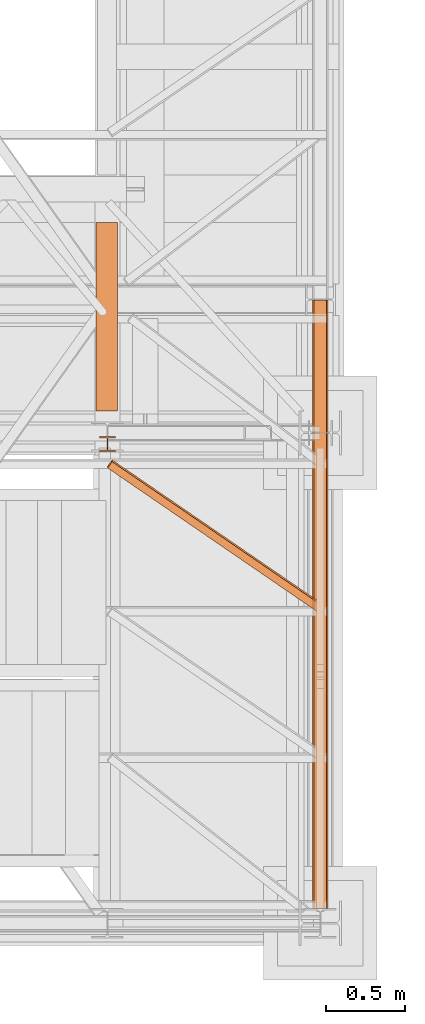
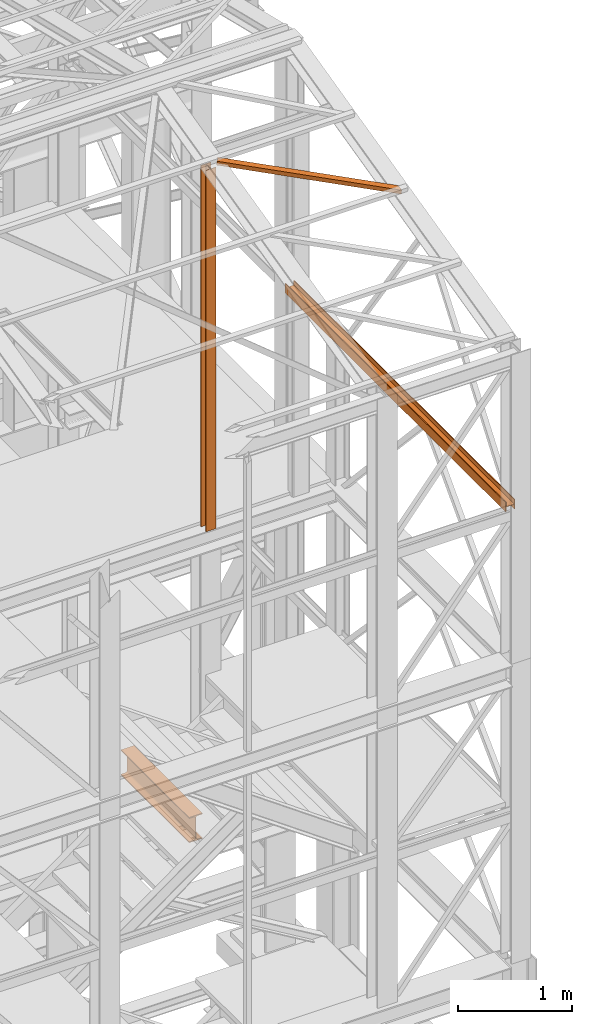
# One storey, part 57 of 208: 5 proxies.
"""IFC2X3 building model written with IfcOpenShell, lengths in millimetres."""

from ifc_helpers import new_model, entity, si_unit, converted_unit, frame, origin, origin_with_axes, place, context, subcontext, project, spatial, faceted_brep, element, save


model = new_model("IFC2X3")

# Units and contexts
model_context = context("Model", 3, precision=1e-05, world=origin())
plan_context = context("Plan", 3, precision=1e-05, world=origin())
body_context = subcontext(model_context, "Body", "Model", "MODEL_VIEW")
ifc_project = project(units=[si_unit("LENGTHUNIT", "METRE", prefix="MILLI"), converted_unit("PLANEANGLEUNIT", "DEGREE", entity("IfcPlaneAngleMeasure", 0.0174532925199433), si_unit("PLANEANGLEUNIT", "RADIAN"), dimensions=[0, 0, 0, 0, 0, 0, 0]), si_unit("AREAUNIT", "SQUARE_METRE"), si_unit("VOLUMEUNIT", "CUBIC_METRE")], contexts=[model_context, plan_context])

# Building, storey
building_placement = place(None, origin())
building = spatial("IfcBuilding", under=ifc_project, at=building_placement, CompositionType="COMPLEX")
storey_placement = place(building_placement, origin_with_axes())
storey = spatial("IfcBuildingStorey", under=building, at=storey_placement, Name="Geschoss", CompositionType="ELEMENT")

# Proxies
proxy_1_placement = place(storey_placement, frame((6650.254968528656, -25077.57438405939, 9979.990000745052), z_axis=(0.0, 0.0, 1.0), x_axis=(1.0, 0.0, 0.0)))
element("IfcBuildingElementProxy", 1, at=proxy_1_placement, inside=storey, context=body_context, shape_type="Brep", body=[
    faceted_brep([(8.010000000000218, 3856.759993674456, 0.01000000000021828), (8.010000000000218, 3856.759993674456, 47.51000000000022), (88.01000000000022, 3856.759993674456, 47.51000000000022), (88.01000000000022, 3856.759993674456, 0.01000000000021828), (96.01000000000022, 3856.759993674456, 0.01000000000021828), (96.01000000000022, 3856.759993674456, 100.0100000000002), (88.01000000000022, 3856.759993674456, 100.0100000000002), (88.01000000000022, 3856.759993674456, 52.51000000000022), (8.010000000000218, 3856.759993674456, 52.51000000000022), (8.010000000000218, 3856.759993674456, 100.0100000000002), (0.01000000000021828, 3856.759993674456, 100.0100000000002), (0.01000000000021828, 3856.759993674456, 0.01000000000021828), (0.01000000000021828, 3856.759993674456, 0.01000000000021828), (0.009999999999308784, 0.01000000000203727, 0.01000000000021828), (8.009999999999309, 0.01000000000203727, 0.01000000000021828), (8.010000000000218, 3856.759993674456, 0.01000000000021828), (0.01000000000021828, 3856.759993674456, 100.0100000000002), (0.009999999999308784, 0.01000000000203727, 100.0100000000002), (0.009999999999308784, 0.01000000000203727, 0.01000000000021828), (0.01000000000021828, 3856.759993674456, 0.01000000000021828), (8.010000000000218, 3856.759993674456, 100.0100000000002), (8.009999999999309, 0.01000000000203727, 100.0100000000002), (0.009999999999308784, 0.01000000000203727, 100.0100000000002), (0.01000000000021828, 3856.759993674456, 100.0100000000002), (8.010000000000218, 3856.759993674456, 52.51000000000022), (8.009999999999309, 0.01000000000203727, 52.51000000000022), (8.009999999999309, 0.01000000000203727, 100.0100000000002), (8.010000000000218, 3856.759993674456, 100.0100000000002), (88.01000000000022, 3856.759993674456, 52.51000000000022), (88.00999999999931, 0.01000000000203727, 52.51000000000022), (8.009999999999309, 0.01000000000203727, 52.51000000000022), (8.010000000000218, 3856.759993674456, 52.51000000000022), (88.01000000000022, 3856.759993674456, 100.0100000000002), (88.00999999999931, 0.01000000000203727, 100.0100000000002), (88.00999999999931, 0.01000000000203727, 52.51000000000022), (88.01000000000022, 3856.759993674456, 52.51000000000022), (96.01000000000022, 3856.759993674456, 100.0100000000002), (96.00999999999931, 0.01000000000203727, 100.0100000000002), (88.00999999999931, 0.01000000000203727, 100.0100000000002), (88.01000000000022, 3856.759993674456, 100.0100000000002), (96.01000000000022, 3856.759993674456, 0.01000000000021828), (96.00999999999931, 0.01000000000203727, 0.01000000000021828), (96.00999999999931, 0.01000000000203727, 100.0100000000002), (96.01000000000022, 3856.759993674456, 100.0100000000002), (88.01000000000022, 3856.759993674456, 0.01000000000021828), (88.00999999999931, 0.01000000000203727, 0.01000000000021828), (96.00999999999931, 0.01000000000203727, 0.01000000000021828), (96.01000000000022, 3856.759993674456, 0.01000000000021828), (88.01000000000022, 3856.759993674456, 47.51000000000022), (88.00999999999931, 0.01000000000203727, 47.51000000000022), (88.00999999999931, 0.01000000000203727, 0.01000000000021828), (88.01000000000022, 3856.759993674456, 0.01000000000021828), (8.010000000000218, 3856.759993674456, 47.51000000000022), (8.009999999999309, 0.01000000000203727, 47.51000000000022), (88.00999999999931, 0.01000000000203727, 47.51000000000022), (88.01000000000022, 3856.759993674456, 47.51000000000022), (8.010000000000218, 3856.759993674456, 0.01000000000021828), (8.009999999999309, 0.01000000000203727, 0.01000000000021828), (8.009999999999309, 0.01000000000203727, 47.51000000000022), (8.010000000000218, 3856.759993674456, 47.51000000000022), (8.009999999999309, 0.01000000000203727, 0.01000000000021828), (0.009999999999308784, 0.01000000000203727, 0.01000000000021828), (0.009999999999308784, 0.01000000000203727, 100.0100000000002), (8.009999999999309, 0.01000000000203727, 100.0100000000002), (8.009999999999309, 0.01000000000203727, 52.51000000000022), (88.00999999999931, 0.01000000000203727, 52.51000000000022), (88.00999999999931, 0.01000000000203727, 100.0100000000002), (96.00999999999931, 0.01000000000203727, 100.0100000000002), (96.00999999999931, 0.01000000000203727, 0.01000000000021828), (88.00999999999931, 0.01000000000203727, 0.01000000000021828), (88.00999999999931, 0.01000000000203727, 47.51000000000022), (8.009999999999309, 0.01000000000203727, 47.51000000000022)], [[[0, 1, 2, 3, 4, 5, 6, 7, 8, 9, 10, 11]], [[12, 13, 14, 15]], [[16, 17, 18, 19]], [[20, 21, 22, 23]], [[24, 25, 26, 27]], [[28, 29, 30, 31]], [[32, 33, 34, 35]], [[36, 37, 38, 39]], [[40, 41, 42, 43]], [[44, 45, 46, 47]], [[48, 49, 50, 51]], [[52, 53, 54, 55]], [[56, 57, 58, 59]], [[60, 61, 62, 63, 64, 65, 66, 67, 68, 69, 70, 71]]], orient=[[False], [False], [False], [False], [False], [False], [False], [False], [False], [False], [False], [False], [False], [False]]),
])
proxy_2_placement = place(storey_placement, frame((6650.254968528656, -25077.57438405939, 9979.990000745052), z_axis=(0.0, 0.0, 1.0), x_axis=(1.0, 0.0, 0.0)))
element("IfcBuildingElementProxy", 2, at=proxy_2_placement, inside=storey, context=body_context, shape_type="Brep", body=[
    faceted_brep([(8.010000000000218, 3856.759993674456, 0.01000000000021828), (8.010000000000218, 3856.759993674456, 47.51000000000022), (88.01000000000022, 3856.759993674456, 47.51000000000022), (88.01000000000022, 3856.759993674456, 0.01000000000021828), (96.01000000000022, 3856.759993674456, 0.01000000000021828), (96.01000000000022, 3856.759993674456, 100.0100000000002), (88.01000000000022, 3856.759993674456, 100.0100000000002), (88.01000000000022, 3856.759993674456, 52.51000000000022), (8.010000000000218, 3856.759993674456, 52.51000000000022), (8.010000000000218, 3856.759993674456, 100.0100000000002), (0.01000000000021828, 3856.759993674456, 100.0100000000002), (0.01000000000021828, 3856.759993674456, 0.01000000000021828), (0.01000000000021828, 3856.759993674456, 0.01000000000021828), (0.009999999999308784, 0.01000000000203727, 0.01000000000021828), (8.009999999999309, 0.01000000000203727, 0.01000000000021828), (8.010000000000218, 3856.759993674456, 0.01000000000021828), (0.01000000000021828, 3856.759993674456, 100.0100000000002), (0.009999999999308784, 0.01000000000203727, 100.0100000000002), (0.009999999999308784, 0.01000000000203727, 0.01000000000021828), (0.01000000000021828, 3856.759993674456, 0.01000000000021828), (8.010000000000218, 3856.759993674456, 100.0100000000002), (8.009999999999309, 0.01000000000203727, 100.0100000000002), (0.009999999999308784, 0.01000000000203727, 100.0100000000002), (0.01000000000021828, 3856.759993674456, 100.0100000000002), (8.010000000000218, 3856.759993674456, 52.51000000000022), (8.009999999999309, 0.01000000000203727, 52.51000000000022), (8.009999999999309, 0.01000000000203727, 100.0100000000002), (8.010000000000218, 3856.759993674456, 100.0100000000002), (88.01000000000022, 3856.759993674456, 52.51000000000022), (88.00999999999931, 0.01000000000203727, 52.51000000000022), (8.009999999999309, 0.01000000000203727, 52.51000000000022), (8.010000000000218, 3856.759993674456, 52.51000000000022), (88.01000000000022, 3856.759993674456, 100.0100000000002), (88.00999999999931, 0.01000000000203727, 100.0100000000002), (88.00999999999931, 0.01000000000203727, 52.51000000000022), (88.01000000000022, 3856.759993674456, 52.51000000000022), (96.01000000000022, 3856.759993674456, 100.0100000000002), (96.00999999999931, 0.01000000000203727, 100.0100000000002), (88.00999999999931, 0.01000000000203727, 100.0100000000002), (88.01000000000022, 3856.759993674456, 100.0100000000002), (96.01000000000022, 3856.759993674456, 0.01000000000021828), (96.00999999999931, 0.01000000000203727, 0.01000000000021828), (96.00999999999931, 0.01000000000203727, 100.0100000000002), (96.01000000000022, 3856.759993674456, 100.0100000000002), (88.01000000000022, 3856.759993674456, 0.01000000000021828), (88.00999999999931, 0.01000000000203727, 0.01000000000021828), (96.00999999999931, 0.01000000000203727, 0.01000000000021828), (96.01000000000022, 3856.759993674456, 0.01000000000021828), (88.01000000000022, 3856.759993674456, 47.51000000000022), (88.00999999999931, 0.01000000000203727, 47.51000000000022), (88.00999999999931, 0.01000000000203727, 0.01000000000021828), (88.01000000000022, 3856.759993674456, 0.01000000000021828), (8.010000000000218, 3856.759993674456, 47.51000000000022), (8.009999999999309, 0.01000000000203727, 47.51000000000022), (88.00999999999931, 0.01000000000203727, 47.51000000000022), (88.01000000000022, 3856.759993674456, 47.51000000000022), (8.010000000000218, 3856.759993674456, 0.01000000000021828), (8.009999999999309, 0.01000000000203727, 0.01000000000021828), (8.009999999999309, 0.01000000000203727, 47.51000000000022), (8.010000000000218, 3856.759993674456, 47.51000000000022), (8.009999999999309, 0.01000000000203727, 0.01000000000021828), (0.009999999999308784, 0.01000000000203727, 0.01000000000021828), (0.009999999999308784, 0.01000000000203727, 100.0100000000002), (8.009999999999309, 0.01000000000203727, 100.0100000000002), (8.009999999999309, 0.01000000000203727, 52.51000000000022), (88.00999999999931, 0.01000000000203727, 52.51000000000022), (88.00999999999931, 0.01000000000203727, 100.0100000000002), (96.00999999999931, 0.01000000000203727, 100.0100000000002), (96.00999999999931, 0.01000000000203727, 0.01000000000021828), (88.00999999999931, 0.01000000000203727, 0.01000000000021828), (88.00999999999931, 0.01000000000203727, 47.51000000000022), (8.009999999999309, 0.01000000000203727, 47.51000000000022)], [[[0, 1, 2, 3, 4, 5, 6, 7, 8, 9, 10, 11]], [[12, 13, 14, 15]], [[16, 17, 18, 19]], [[20, 21, 22, 23]], [[24, 25, 26, 27]], [[28, 29, 30, 31]], [[32, 33, 34, 35]], [[36, 37, 38, 39]], [[40, 41, 42, 43]], [[44, 45, 46, 47]], [[48, 49, 50, 51]], [[52, 53, 54, 55]], [[56, 57, 58, 59]], [[60, 61, 62, 63, 64, 65, 66, 67, 68, 69, 70, 71]]], orient=[[False], [False], [False], [False], [False], [False], [False], [False], [False], [False], [False], [False], [False], [False]]),
])
proxy_3_placement = place(storey_placement, frame((5349.415251226796, -23201.62230478293, 12214.24717333412), z_axis=(0.0, 0.0, 1.0), x_axis=(1.0, 0.0, 0.0)))
element("IfcBuildingElementProxy", 3, at=proxy_3_placement, inside=storey, context=body_context, shape_type="Brep", body=[
    faceted_brep([(28.82079669527775, 967.7692788621025, 232.0521250666225), (28.82079669527775, 955.9752131652676, 280.6412186405796), (0.01000000000021828, 916.2634686381462, 271.0019582749592), (0.01000000000021828, 928.0575343349847, 222.4128647010039), (1337.349720073478, 71.25499243027298, 14.44056628674844), (1337.349720073478, 59.4609267334381, 63.02965986070558), (28.82079669527775, 955.9752131652676, 280.6412186405796), (28.82079669527775, 967.7692788621025, 232.0521250666225), (1337.349720073478, 11.80406569683692, 0.01000000000021828), (1337.349720073478, 71.25499243027298, 14.44056628674844), (28.82079669527775, 967.7692788621025, 232.0521250666225), (0.01000000000021828, 928.0575343349847, 222.4128647010039), (1337.349720073478, 0.00999999999839929, 48.59909357395554), (1337.349720073478, 11.80406569683692, 0.01000000000021828), (0.01000000000021828, 928.0575343349847, 222.4128647010039), (0.01000000000021828, 916.2634686381462, 271.0019582749592), (1337.349720073478, 59.4609267334381, 63.02965986070558), (1337.349720073478, 0.00999999999839929, 48.59909357395554), (0.01000000000021828, 916.2634686381462, 271.0019582749592), (28.82079669527775, 955.9752131652676, 280.6412186405796), (1337.349720073478, 71.25499243027298, 14.44056628674844), (1337.349720073478, 11.80406569683692, 0.01000000000021828), (1337.349720073478, 0.00999999999839929, 48.59909357395554), (1337.349720073478, 59.4609267334381, 63.02965986070558)], [[[0, 1, 2, 3]], [[4, 5, 6, 7]], [[8, 9, 10, 11]], [[12, 13, 14, 15]], [[16, 17, 18, 19]], [[20, 21, 22, 23]]], orient=[[False], [False], [False], [False], [False], [False]]),
])
proxy_4_placement = place(storey_placement, frame((5276.754968338675, -21922.57438972184, 5014.990005364415), z_axis=(0.0, 0.0, 1.0), x_axis=(1.0, 0.0, 0.0)))
element("IfcBuildingElementProxy", 4, at=proxy_4_placement, inside=storey, context=body_context, shape_type="Brep", body=[
    faceted_brep([(135.0100000000002, 0.01000000000203727, 270.0100000000002), (135.0100000000002, 1194.009999593949, 270.0100000000002), (135.0100000000002, 1194.009999593949, 259.8100001907351), (135.0100000000002, 0.01000000000203727, 259.8100001907351), (135.0100000000002, 0.01000000000203727, 259.8100001907351), (135.0100000000002, 1194.009999593949, 259.8100001907351), (85.80999995231468, 1194.009999593945, 259.810000190736), (85.8099999523165, 0.01000000000203727, 259.8100001907351), (85.8099999523165, 0.01000000000203727, 259.8100001907351), (85.80999995231468, 1194.009999593945, 259.810000190736), (81.17476076017101, 1194.009999593949, 259.0757968253238), (81.17476076017192, 0.01000000000203727, 259.0757968253238), (81.17476076017192, 0.01000000000203727, 259.0757968253238), (81.17476076017101, 1194.009999593949, 259.0757968253238), (76.99323602687218, 1194.009999593945, 256.9452365592924), (76.99323602687218, 0.01000000000203727, 256.9452365592924), (76.99323602687218, 0.01000000000203727, 256.9452365592924), (76.99323602687218, 1194.009999593945, 256.9452365592924), (73.67476358375916, 1194.009999593949, 253.6267641161803), (73.67476358376007, 0.01000000000203727, 253.6267641161803), (73.67476358376007, 0.01000000000203727, 253.6267641161803), (73.67476358375916, 1194.009999593949, 253.6267641161803), (71.5442033177278, 1194.009999593949, 249.4452393828797), (71.5442033177278, 0.01000000000203727, 249.4452393828788), (71.5442033177278, 0.01000000000203727, 249.4452393828788), (71.5442033177278, 1194.009999593949, 249.4452393828797), (70.8099999523165, 1194.009999593949, 244.8100001907351), (70.8099999523165, 0.01000000000203727, 244.8100001907351), (70.8099999523165, 0.01000000000203727, 244.8100001907351), (70.8099999523165, 1194.009999593949, 244.8100001907351), (70.8099999523156, 1194.009999593949, 25.20999980926536), (70.8099999523165, 0.01000000000203727, 25.20999980926536), (70.8099999523165, 0.01000000000203727, 25.20999980926536), (70.8099999523156, 1194.009999593949, 25.20999980926536), (71.5442033177278, 1194.009999593949, 20.57476061712077), (71.5442033177278, 0.01000000000203727, 20.57476061712077), (71.5442033177278, 0.01000000000203727, 20.57476061712077), (71.5442033177278, 1194.009999593949, 20.57476061712077), (73.67476358376007, 1194.009999593949, 16.39323588382013), (73.67476358376007, 0.01000000000203727, 16.39323588382013), (73.67476358376007, 0.01000000000203727, 16.39323588382013), (73.67476358376007, 1194.009999593949, 16.39323588382013), (76.99323602687218, 1194.009999593949, 13.07476344070892), (76.99323602687218, 0.01000000000203727, 13.07476344070801), (76.99323602687218, 0.01000000000203727, 13.07476344070801), (76.99323602687218, 1194.009999593949, 13.07476344070892), (81.17476076017192, 1194.009999593949, 10.94420317467757), (81.17476076017192, 0.01000000000203727, 10.94420317467666), (81.17476076017192, 0.01000000000203727, 10.94420317467666), (81.17476076017192, 1194.009999593949, 10.94420317467757), (85.8099999523165, 1194.009999593949, 10.20999980926536), (85.8099999523165, 0.01000000000203727, 10.20999980926536), (85.8099999523165, 0.01000000000203727, 10.20999980926536), (85.8099999523165, 1194.009999593949, 10.20999980926536), (135.0100000000002, 1194.009999593949, 10.20999980926536), (135.0100000000002, 0.01000000000203727, 10.20999980926536), (135.0100000000002, 0.01000000000203727, 10.20999980926536), (135.0100000000002, 1194.009999593949, 10.20999980926536), (135.0100000000002, 1194.009999593949, 0.01000000000021828), (135.0100000000002, 0.01000000000203727, 0.01000000000112777), (135.0100000000002, 0.01000000000203727, 0.01000000000112777), (135.0100000000002, 1194.009999593949, 0.01000000000021828), (0.01000000000021828, 1194.009999593949, 0.01000000000021828), (0.01000000000021828, 0.01000000000203727, 0.01000000000112777), (0.01000000000021828, 0.01000000000203727, 0.01000000000112777), (0.01000000000021828, 1194.009999593949, 0.01000000000021828), (0.01000000000021828, 1194.009999593949, 10.20999980926626), (0.01000000000021828, 0.01000000000203727, 10.20999980926536), (0.01000000000021828, 0.01000000000203727, 10.20999980926536), (0.01000000000021828, 1194.009999593949, 10.20999980926626), (49.21000004768393, 1194.009999593949, 10.20999980926536), (49.21000004768393, 0.01000000000203727, 10.20999980926536), (49.21000004768393, 0.01000000000203727, 10.20999980926536), (49.21000004768393, 1194.009999593949, 10.20999980926536), (53.09227270367046, 1194.009999593949, 10.72115637176194), (53.09227270367046, 0.01000000000203727, 10.72115637176194), (53.09227270367046, 0.01000000000203727, 10.72115637176194), (53.09227270367046, 1194.009999593949, 10.72115637176194), (56.70997817243006, 1194.009999593949, 12.21965904159242), (56.70997817243006, 0.01000000000203727, 12.21965904159242), (56.70997817243006, 0.01000000000203727, 12.21965904159242), (56.70997817243006, 1194.009999593949, 12.21965904159242), (59.81660176548212, 1194.009999593949, 14.60339809146717), (59.81660176548212, 0.01000000000203727, 14.60339809146717), (59.81660176548212, 0.01000000000203727, 14.60339809146717), (59.81660176548212, 1194.009999593949, 14.60339809146717), (62.20034081535596, 1194.009999593949, 17.71002168452014), (62.20034081535596, 0.01000000000203727, 17.71002168452014), (62.20034081535596, 0.01000000000203727, 17.71002168452014), (62.20034081535596, 1194.009999593949, 17.71002168452014), (63.69884348518826, 1194.009999593949, 21.32772715327792), (63.69884348518826, 0.01000000000203727, 21.32772715327792), (63.69884348518826, 0.01000000000203727, 21.32772715327792), (63.69884348518826, 1194.009999593949, 21.32772715327792), (64.21000004768393, 1194.009999593949, 25.20999980926536), (64.21000004768393, 0.01000000000203727, 25.20999980926536), (64.21000004768393, 0.01000000000203727, 25.20999980926536), (64.21000004768393, 1194.009999593949, 25.20999980926536), (64.21000004768393, 1194.009999593949, 244.8100001907351), (64.21000004768393, 0.01000000000203727, 244.8100001907351), (64.21000004768393, 0.01000000000203727, 244.8100001907351), (64.21000004768393, 1194.009999593949, 244.8100001907351), (63.47579668227263, 1194.009999593949, 249.4452393828797), (63.47579668227263, 0.01000000000203727, 249.4452393828788), (63.47579668227263, 0.01000000000203727, 249.4452393828788), (63.47579668227263, 1194.009999593949, 249.4452393828797), (61.34523641624037, 1194.009999593949, 253.6267641161803), (61.34523641624037, 0.01000000000203727, 253.6267641161803), (61.34523641624037, 0.01000000000203727, 253.6267641161803), (61.34523641624037, 1194.009999593949, 253.6267641161803), (58.02676397313007, 1194.009999593945, 256.9452365592924), (58.02676397313007, 0.01000000000203727, 256.9452365592924), (58.02676397313007, 0.01000000000203727, 256.9452365592924), (58.02676397313007, 1194.009999593945, 256.9452365592924), (53.84523923982852, 1194.009999593949, 259.0757968253229), (53.84523923982852, 0.01000000000203727, 259.0757968253238), (53.84523923982852, 0.01000000000203727, 259.0757968253238), (53.84523923982852, 1194.009999593949, 259.0757968253229), (49.21000004768393, 1194.009999593945, 259.810000190736), (49.21000004768393, 0.01000000000203727, 259.8100001907351), (49.21000004768393, 0.01000000000203727, 259.8100001907351), (49.21000004768393, 1194.009999593945, 259.810000190736), (0.01000000000021828, 1194.009999593949, 259.810000190736), (0.01000000000021828, 0.01000000000203727, 259.8100001907351), (0.01000000000021828, 0.01000000000203727, 259.8100001907351), (0.01000000000021828, 1194.009999593949, 259.810000190736), (0.01000000000021828, 1194.009999593945, 270.0100000000002), (0.01000000000021828, 0.01000000000203727, 270.0100000000002), (0.01000000000021828, 0.01000000000203727, 270.0100000000002), (0.01000000000021828, 1194.009999593945, 270.0100000000002), (135.0100000000002, 1194.009999593949, 270.0100000000002), (135.0100000000002, 0.01000000000203727, 270.0100000000002), (135.0100000000002, 0.01000000000203727, 270.0100000000002), (135.0100000000002, 0.01000000000203727, 259.8100001907351), (85.8099999523165, 0.01000000000203727, 259.8100001907351), (81.17476076017192, 0.01000000000203727, 259.0757968253238), (76.99323602687218, 0.01000000000203727, 256.9452365592924), (73.67476358376007, 0.01000000000203727, 253.6267641161803), (71.5442033177278, 0.01000000000203727, 249.4452393828788), (70.8099999523165, 0.01000000000203727, 244.8100001907351), (70.8099999523165, 0.01000000000203727, 25.20999980926536), (71.5442033177278, 0.01000000000203727, 20.57476061712077), (73.67476358376007, 0.01000000000203727, 16.39323588382013), (76.99323602687218, 0.01000000000203727, 13.07476344070801), (81.17476076017192, 0.01000000000203727, 10.94420317467666), (85.8099999523165, 0.01000000000203727, 10.20999980926536), (135.0100000000002, 0.01000000000203727, 10.20999980926536), (135.0100000000002, 0.01000000000203727, 0.01000000000112777), (0.01000000000021828, 0.01000000000203727, 0.01000000000112777), (0.01000000000021828, 0.01000000000203727, 10.20999980926536), (49.21000004768393, 0.01000000000203727, 10.20999980926536), (53.09227270367046, 0.01000000000203727, 10.72115637176194), (56.70997817243006, 0.01000000000203727, 12.21965904159242), (59.81660176548212, 0.01000000000203727, 14.60339809146717), (62.20034081535596, 0.01000000000203727, 17.71002168452014), (63.69884348518826, 0.01000000000203727, 21.32772715327792), (64.21000004768393, 0.01000000000203727, 25.20999980926536), (64.21000004768393, 0.01000000000203727, 244.8100001907351), (63.47579668227263, 0.01000000000203727, 249.4452393828788), (61.34523641624037, 0.01000000000203727, 253.6267641161803), (58.02676397313007, 0.01000000000203727, 256.9452365592924), (53.84523923982852, 0.01000000000203727, 259.0757968253238), (49.21000004768393, 0.01000000000203727, 259.8100001907351), (0.01000000000021828, 0.01000000000203727, 259.8100001907351), (0.01000000000021828, 0.01000000000203727, 270.0100000000002), (73.67476358375916, 1194.009999593949, 253.6267641161803), (76.99323602687218, 1194.009999593945, 256.9452365592924), (81.17476076017101, 1194.009999593949, 259.0757968253238), (85.80999995231468, 1194.009999593945, 259.810000190736), (135.0100000000002, 1194.009999593949, 259.8100001907351), (135.0100000000002, 1194.009999593949, 270.0100000000002), (0.01000000000021828, 1194.009999593945, 270.0100000000002), (0.01000000000021828, 1194.009999593949, 259.810000190736), (49.21000004768393, 1194.009999593945, 259.810000190736), (53.84523923982852, 1194.009999593949, 259.0757968253229), (58.02676397313007, 1194.009999593945, 256.9452365592924), (61.34523641624037, 1194.009999593949, 253.6267641161803), (63.47579668227263, 1194.009999593949, 249.4452393828797), (64.21000004768393, 1194.009999593949, 244.8100001907351), (64.21000004768393, 1194.009999593949, 25.20999980926536), (63.69884348518826, 1194.009999593949, 21.32772715327792), (62.20034081535596, 1194.009999593949, 17.71002168452014), (59.81660176548212, 1194.009999593949, 14.60339809146717), (56.70997817243006, 1194.009999593949, 12.21965904159242), (53.09227270367046, 1194.009999593949, 10.72115637176194), (49.21000004768393, 1194.009999593949, 10.20999980926536), (0.01000000000021828, 1194.009999593949, 10.20999980926626), (0.01000000000021828, 1194.009999593949, 0.01000000000021828), (135.0100000000002, 1194.009999593949, 0.01000000000021828), (135.0100000000002, 1194.009999593949, 10.20999980926536), (85.8099999523165, 1194.009999593949, 10.20999980926536), (81.17476076017192, 1194.009999593949, 10.94420317467757), (76.99323602687218, 1194.009999593949, 13.07476344070892), (73.67476358376007, 1194.009999593949, 16.39323588382013), (71.5442033177278, 1194.009999593949, 20.57476061712077), (70.8099999523156, 1194.009999593949, 25.20999980926536), (70.8099999523165, 1194.009999593949, 244.8100001907351), (71.5442033177278, 1194.009999593949, 249.4452393828797)], [[[0, 1, 2, 3]], [[4, 5, 6, 7]], [[8, 9, 10, 11]], [[12, 13, 14, 15]], [[16, 17, 18, 19]], [[20, 21, 22, 23]], [[24, 25, 26, 27]], [[28, 29, 30, 31]], [[32, 33, 34, 35]], [[36, 37, 38, 39]], [[40, 41, 42, 43]], [[44, 45, 46, 47]], [[48, 49, 50, 51]], [[52, 53, 54, 55]], [[56, 57, 58, 59]], [[60, 61, 62, 63]], [[64, 65, 66, 67]], [[68, 69, 70, 71]], [[72, 73, 74, 75]], [[76, 77, 78, 79]], [[80, 81, 82, 83]], [[84, 85, 86, 87]], [[88, 89, 90, 91]], [[92, 93, 94, 95]], [[96, 97, 98, 99]], [[100, 101, 102, 103]], [[104, 105, 106, 107]], [[108, 109, 110, 111]], [[112, 113, 114, 115]], [[116, 117, 118, 119]], [[120, 121, 122, 123]], [[124, 125, 126, 127]], [[128, 129, 130, 131]], [[132, 133, 134, 135, 136, 137, 138, 139, 140, 141, 142, 143, 144, 145, 146, 147, 148, 149, 150, 151, 152, 153, 154, 155, 156, 157, 158, 159, 160, 161, 162, 163, 164]], [[165, 166, 167, 168, 169, 170, 171, 172, 173, 174, 175, 176, 177, 178, 179, 180, 181, 182, 183, 184, 185, 186, 187, 188, 189, 190, 191, 192, 193, 194, 195, 196, 197]]], orient=[[False], [False], [False], [False], [False], [False], [False], [False], [False], [False], [False], [False], [False], [False], [False], [False], [False], [False], [False], [False], [False], [False], [False], [False], [False], [False], [False], [False], [False], [False], [False], [False], [False], [False], [False]]),
])
proxy_5_placement = place(storey_placement, frame((5298.319663719517, -22182.57439508626, 8484.990002086157), z_axis=(0.0, 0.0, 1.0), x_axis=(1.0, 0.0, 0.0)))
element("IfcBuildingElementProxy", 5, at=proxy_5_placement, inside=storey, context=body_context, shape_type="Brep", body=[
    faceted_brep([(0.01000000000021828, 8.0099999999984, 0.01000000000021828), (0.01000000000021828, 0.00999999999839929, 0.01000000000021828), (100.0100000000002, 0.00999999999839929, 0.01000000000021828), (100.0100000000002, 8.0099999999984, 0.01000000000021828), (52.51000000000022, 8.0099999999984, 0.01000000000021828), (52.51000000000022, 88.0099999999984, 0.01000000000021828), (100.0100000000002, 88.0099999999984, 0.01000000000021828), (100.0100000000002, 96.0099999999984, 0.01000000000021828), (0.01000000000021828, 96.0099999999984, 0.01000000000021828), (0.01000000000021828, 88.0099999999984, 0.01000000000021828), (47.51000000000022, 88.0099999999984, 0.01000000000021828), (47.51000000000022, 8.0099999999984, 0.01000000000021828), (0.01000000000021828, 0.00999999999839929, 0.01000000000021828), (0.01000000000021828, 8.0099999999984, 0.01000000000021828), (0.01000000000203727, 8.0099999999984, 3855.922025344464), (0.01000000000203727, 0.00999999999839929, 3855.922025344464), (100.0100000000002, 0.00999999999839929, 0.01000000000021828), (0.01000000000021828, 0.00999999999839929, 0.01000000000021828), (0.01000000000203727, 0.00999999999839929, 3855.922025344464), (100.010000000002, 0.00999999999839929, 3855.922025344464), (100.0100000000002, 8.0099999999984, 0.01000000000021828), (100.0100000000002, 0.00999999999839929, 0.01000000000021828), (100.010000000002, 0.00999999999839929, 3855.922025344464), (100.010000000002, 8.0099999999984, 3855.922025344464), (52.51000000000022, 8.0099999999984, 0.01000000000021828), (100.0100000000002, 8.0099999999984, 0.01000000000021828), (100.010000000002, 8.0099999999984, 3855.922025344464), (52.51000000000204, 8.0099999999984, 3855.922025344464), (52.51000000000022, 88.0099999999984, 0.01000000000021828), (52.51000000000022, 8.0099999999984, 0.01000000000021828), (52.51000000000204, 8.0099999999984, 3855.922025344464), (52.51000000000204, 88.0099999999984, 3855.922025344464), (100.0100000000002, 88.0099999999984, 0.01000000000021828), (52.51000000000022, 88.0099999999984, 0.01000000000021828), (52.51000000000204, 88.0099999999984, 3855.922025344464), (100.010000000002, 88.0099999999984, 3855.922025344464), (100.0100000000002, 96.0099999999984, 0.01000000000021828), (100.0100000000002, 88.0099999999984, 0.01000000000021828), (100.010000000002, 88.0099999999984, 3855.922025344464), (100.010000000002, 96.0099999999984, 3855.922025344464), (0.01000000000021828, 96.0099999999984, 0.01000000000021828), (100.0100000000002, 96.0099999999984, 0.01000000000021828), (100.010000000002, 96.0099999999984, 3855.922025344464), (0.01000000000203727, 96.0099999999984, 3855.922025344464), (0.01000000000021828, 88.0099999999984, 0.01000000000021828), (0.01000000000021828, 96.0099999999984, 0.01000000000021828), (0.01000000000203727, 96.0099999999984, 3855.922025344464), (0.01000000000203727, 88.0099999999984, 3855.922025344464), (47.51000000000022, 88.0099999999984, 0.01000000000021828), (0.01000000000021828, 88.0099999999984, 0.01000000000021828), (0.01000000000203727, 88.0099999999984, 3855.922025344464), (47.51000000000204, 88.0099999999984, 3855.922025344464), (47.51000000000022, 8.0099999999984, 0.01000000000021828), (47.51000000000022, 88.0099999999984, 0.01000000000021828), (47.51000000000204, 88.0099999999984, 3855.922025344464), (47.51000000000204, 8.0099999999984, 3855.922025344464), (0.01000000000021828, 8.0099999999984, 0.01000000000021828), (47.51000000000022, 8.0099999999984, 0.01000000000021828), (47.51000000000204, 8.0099999999984, 3855.922025344464), (0.01000000000203727, 8.0099999999984, 3855.922025344464), (0.01000000000203727, 8.0099999999984, 3855.922025344464), (47.51000000000204, 8.0099999999984, 3855.922025344464), (47.51000000000204, 88.0099999999984, 3855.922025344464), (0.01000000000203727, 88.0099999999984, 3855.922025344464), (0.01000000000203727, 96.0099999999984, 3855.922025344464), (100.010000000002, 96.0099999999984, 3855.922025344464), (100.010000000002, 88.0099999999984, 3855.922025344464), (52.51000000000204, 88.0099999999984, 3855.922025344464), (52.51000000000204, 8.0099999999984, 3855.922025344464), (100.010000000002, 8.0099999999984, 3855.922025344464), (100.010000000002, 0.00999999999839929, 3855.922025344464), (0.01000000000203727, 0.00999999999839929, 3855.922025344464)], [[[0, 1, 2, 3, 4, 5, 6, 7, 8, 9, 10, 11]], [[12, 13, 14, 15]], [[16, 17, 18, 19]], [[20, 21, 22, 23]], [[24, 25, 26, 27]], [[28, 29, 30, 31]], [[32, 33, 34, 35]], [[36, 37, 38, 39]], [[40, 41, 42, 43]], [[44, 45, 46, 47]], [[48, 49, 50, 51]], [[52, 53, 54, 55]], [[56, 57, 58, 59]], [[60, 61, 62, 63, 64, 65, 66, 67, 68, 69, 70, 71]]], orient=[[False], [False], [False], [False], [False], [False], [False], [False], [False], [False], [False], [False], [False], [False]]),
])

save(model, "model.ifc")
